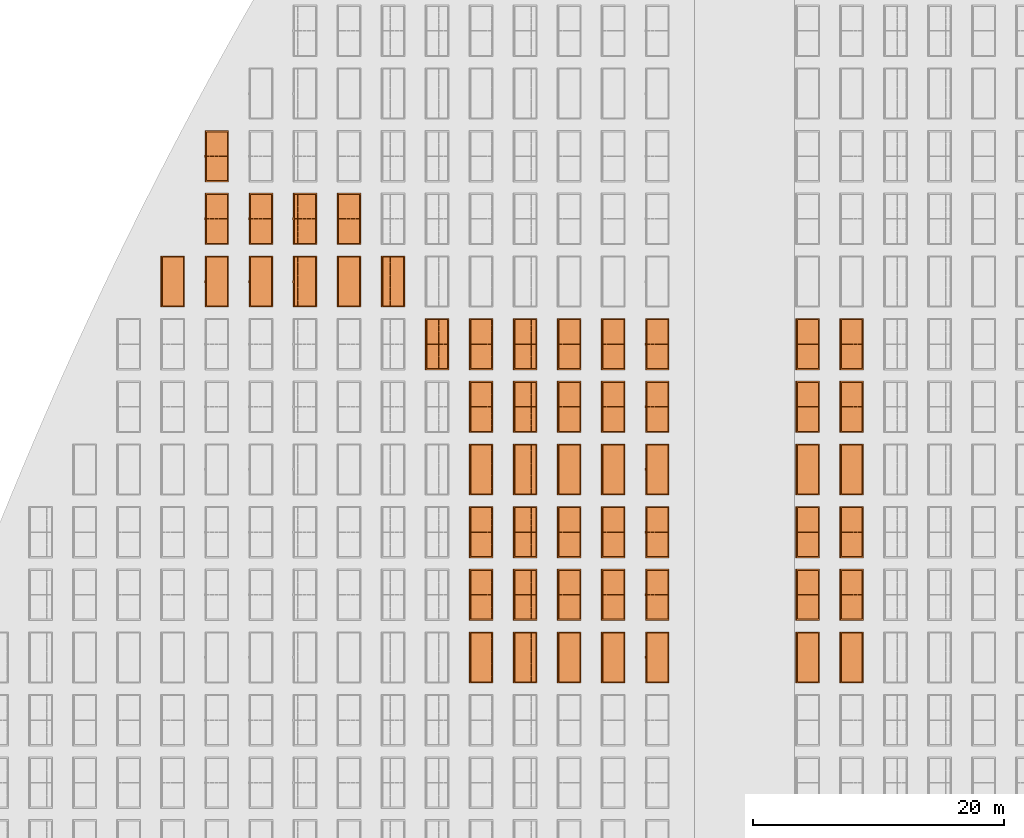
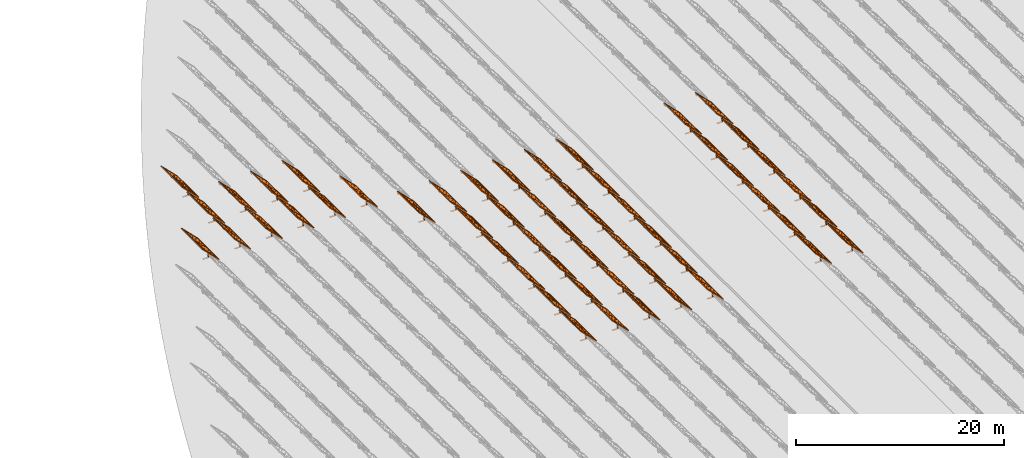
# One storey, part 28 of 39: 54 proxies.
"""IFC2X3 building model written with IfcOpenShell, lengths in millimetres."""

from ifc_helpers import new_model, entity, si_unit, converted_unit, derived_unit, direction, frame, frame_2d, origin, origin_2d_with_axis, place, context, subcontext, project, spatial, polyline, rectangle, outline, extrude, source, transform, mapped, material, material_list, element, save


model = new_model("IFC2X3")

# Units and contexts
model_context = context("Model", 3, precision=1e-06, world=origin(), true_north=direction((2.0, 6.12303176911189e-17, 1.0)))
context_of_model = context(None, 3, precision=1e-06, world=origin(), true_north=direction((2.0, 6.12303176911189e-17, 1.0)))
body_context = subcontext(model_context, "Body", "Model", "MODEL_VIEW")
ifc_project = project(units=[si_unit("LENGTHUNIT", "METRE", prefix="MILLI"), si_unit("AREAUNIT", "SQUARE_METRE", prefix="MILLI"), si_unit("VOLUMEUNIT", "CUBIC_METRE", prefix="MILLI"), converted_unit("PLANEANGLEUNIT", "DEGREE", entity("IfcRatioMeasure", 0.0174532925199433), si_unit("PLANEANGLEUNIT", "RADIAN"), dimensions=[0, 0, 0, 0, 0, 0, 0]), si_unit("MASSUNIT", "GRAM", prefix="KILO"), si_unit("TIMEUNIT", "SECOND"), si_unit("THERMODYNAMICTEMPERATUREUNIT", "KELVIN"), derived_unit("THERMALTRANSMITTANCEUNIT", [(si_unit("MASSUNIT", "GRAM", prefix="KILO"), 1), (si_unit("THERMODYNAMICTEMPERATUREUNIT", "KELVIN"), -1), (si_unit("TIMEUNIT", "SECOND"), -3)]), derived_unit("VOLUMETRICFLOWRATEUNIT", [(si_unit("LENGTHUNIT", "METRE"), 3), (si_unit("TIMEUNIT", "SECOND"), -1)])], contexts=[model_context, context_of_model])

# Site, building, storey
site_placement = place(None, origin())
site = spatial("IfcSite", under=ifc_project, at=site_placement, CompositionType="ELEMENT")
building_placement = place(site_placement, origin())
building = spatial("IfcBuilding", under=site, at=building_placement, CompositionType="ELEMENT")
storey_placement = place(building_placement, frame((0.0, 0.0, 4000.0)))
storey = spatial("IfcBuildingStorey", under=building, at=storey_placement, Name="Level 2", CompositionType="ELEMENT", Elevation=4000.0)

# Proxies
ifc_material_1 = material(Name="Stand-Steel")
ifc_material_2 = material(Name="Aluminium")
ifc_material_3 = material(Name="Glass")
ifc_material_list_1 = material_list([ifc_material_1, ifc_material_2, ifc_material_3])
shared_shape = source(origin(), body_context, "Body", "SweptSolid", [
    extrude(outline(polyline([(-629.526235435404, -220.0), (329.763117717702, -220.0), (329.763117717703, 410.0), (299.763117717703, 410.0), (299.763117717702, -190.0), (-629.526235435404, -190.0), (-629.526235435404, -220.0)])), frame((-190.00003127179, -100.0, 299.763117717707), z_axis=(0.0, 1.0, 0.0), x_axis=(0.0, 0.0, -1.0)), (0.0, 0.0, 1.0), 200.0),
    extrude(rectangle(XDim=20.0000000000001, YDim=200.0, at=frame_2d((0.0, -7.105427357601e-14), x_axis=(0.0, 1.0))), frame((-7.07109908365613, 0.0, 922.21828534124), z_axis=(-0.70710678118654, 0.0, 0.707106781186555), x_axis=(0.0, 1.0, 0.0)), (0.0, 0.0, 1.0), 2600.0),
    extrude(rectangle(XDim=24.9999999999997, YDim=24.9999999999999, at=frame_2d((2.87769807982841e-13, -9.50350909079134e-14), x_axis=(1.0, 0.0))), frame((-1449.56292018118, -1950.0, 2449.57494522722), z_axis=(0.0, 1.0, 0.0), x_axis=(-0.707106781186548, 0.0, -0.707106781186548)), (0.0, 0.0, 1.0), 3900.0),
    extrude(rectangle(XDim=24.9999999999999, YDim=25.0000000000001, at=origin_2d_with_axis()), frame((-1096.0095295879, -1950.0, 2096.02155463395), z_axis=(0.0, 1.0, 0.0), x_axis=(-0.707106781186542, 0.0, -0.707106781186553)), (0.0, 0.0, 1.0), 3900.0),
    extrude(rectangle(XDim=24.9999999999999, YDim=25.0000000000001, at=origin_2d_with_axis()), frame((-742.456138994631, -1950.0, 1742.46816404067), z_axis=(0.0, 1.0, 0.0), x_axis=(-0.707106781186542, 0.0, -0.707106781186553)), (0.0, 0.0, 1.0), 3900.0),
    extrude(rectangle(XDim=25.0, YDim=24.9999999999997, at=frame_2d((-7.19424519957101e-14, 1.19904086659517e-13), x_axis=(1.0, 0.0))), frame((-388.902748401358, -1950.0, 1388.9147734474), z_axis=(0.0, 1.0, 0.0), x_axis=(-0.707106781186545, 0.0, -0.70710678118655)), (0.0, 0.0, 1.0), 3900.0),
    extrude(rectangle(XDim=25.0000000000002, YDim=25.0, at=frame_2d((1.35891298214119e-13, 6.21724893790088e-15), x_axis=(0.0, 1.0))), frame((-35.3553703311048, 1500.0, 1035.35537033109), z_axis=(-0.707106781186544, 0.0, 0.707106781186551), x_axis=(0.0, 1.0, 0.0)), (0.0, 0.0, 1.0), 2440.0),
    extrude(rectangle(XDim=25.0000000000002, YDim=25.0, at=frame_2d((0.0, 1.77635683940025e-15), x_axis=(0.0, 1.0))), frame((-35.3553703311059, 1000.0, 1035.35537033109), z_axis=(-0.707106781186546, 0.0, 0.707106781186549), x_axis=(0.0, 1.0, 0.0)), (0.0, 0.0, 1.0), 2440.0),
    extrude(rectangle(XDim=25.0000000000002, YDim=25.0, at=frame_2d((0.0, 8.43769498715119e-14), x_axis=(0.0, 1.0))), frame((-26.5165355662756, 0.0, 1044.19420509593), z_axis=(-0.707106781186546, 0.0, 0.707106781186549), x_axis=(0.0, -1.0, 0.0)), (0.0, 0.0, 1.0), 2440.0),
    extrude(rectangle(XDim=25.0000000000002, YDim=25.0, at=frame_2d((0.0, 8.88178419700125e-16), x_axis=(0.0, 1.0))), frame((-35.3553703311065, 500.0, 1035.35537033109), z_axis=(-0.707106781186546, 0.0, 0.707106781186549), x_axis=(0.0, 1.0, 0.0)), (0.0, 0.0, 1.0), 2440.0),
    extrude(rectangle(XDim=25.0000000000002, YDim=25.0, at=frame_2d((0.0, 8.88178419700125e-16), x_axis=(0.0, 1.0))), frame((-35.3553703311086, -500.0, 1035.35537033109), z_axis=(-0.707106781186546, 0.0, 0.707106781186549), x_axis=(0.0, 1.0, 0.0)), (0.0, 0.0, 1.0), 2440.0),
    extrude(rectangle(XDim=25.0000000000002, YDim=25.0, at=frame_2d((0.0, 8.88178419700125e-16), x_axis=(0.0, 1.0))), frame((-35.3553703311095, -1000.0, 1035.35537033109), z_axis=(-0.707106781186546, 0.0, 0.707106781186549), x_axis=(0.0, 1.0, 0.0)), (0.0, 0.0, 1.0), 2440.0),
    extrude(rectangle(XDim=25.0000000000002, YDim=25.0, at=frame_2d((1.35891298214119e-13, 1.77635683940025e-15), x_axis=(0.0, 1.0))), frame((-35.3553703311107, -1500.0, 1035.35537033109), z_axis=(-0.707106781186546, 0.0, 0.707106781186549), x_axis=(0.0, 1.0, 0.0)), (0.0, 0.0, 1.0), 2440.0),
    extrude(rectangle(XDim=2400.0, YDim=11.9999999999994, at=frame_2d((-1.13686837721616e-13, 2.02948768901479e-13), x_axis=(1.0, 0.0))), frame((-883.883507754966, -1950.0, 1883.88350775495), z_axis=(0.0, 1.0, 0.0), x_axis=(0.707106781186546, 0.0, -0.707106781186549)), (0.0, 0.0, 1.0), 3900.0),
    extrude(outline(polyline([(-2050.0, -1300.0), (2050.0, -1300.0), (2050.0, 1300.0), (-2050.0, 1300.0), (-2050.0, -1300.0)]), holes=[polyline([(1950.0, -1200.0), (-1950.0, -1200.0), (-1950.0, 1200.0), (1950.0, 1200.0), (1950.0, -1200.0)])]), frame((-919.238846814293, 0.0, 1848.52816869563), z_axis=(0.707106781186554, 0.0, 0.707106781186541), x_axis=(0.0, 1.0, 0.0)), (0.0, 0.0, 1.0), 99.9999999999898),
])
proxy_1_placement = place(storey_placement, frame((-144385.32831183, 565144.680552408, 30.0)))
element("IfcBuildingElementProxy", 1, at=proxy_1_placement, inside=storey, material=ifc_material_list_1, Name="Solar Panel_4000X2500:Solar Panel_4000X2500", ObjectType="Solar Panel_4000X2500", CompositionType="ELEMENT", context=body_context, shape_type="MappedRepresentation", body=[
    mapped(shared_shape, transform((0.0, 0.0, 0.0), scale=1.0)),
])
ifc_material_list_2 = material_list([ifc_material_1, ifc_material_2, ifc_material_3])
proxy_2_placement = place(storey_placement, frame((-144385.32831183, 570144.680552408, 30.0)))
element("IfcBuildingElementProxy", 2, at=proxy_2_placement, inside=storey, material=ifc_material_list_2, Name="Solar Panel_4000X2500:Solar Panel_4000X2500", ObjectType="Solar Panel_4000X2500", CompositionType="ELEMENT", context=body_context, shape_type="MappedRepresentation", body=[
    mapped(shared_shape, transform((0.0, 0.0, 0.0), scale=1.0)),
])
ifc_material_list_3 = material_list([ifc_material_1, ifc_material_2, ifc_material_3])
proxy_3_placement = place(storey_placement, frame((-144385.32831183, 575144.680552408, 30.0)))
element("IfcBuildingElementProxy", 3, at=proxy_3_placement, inside=storey, material=ifc_material_list_3, Name="Solar Panel_4000X2500:Solar Panel_4000X2500", ObjectType="Solar Panel_4000X2500", CompositionType="ELEMENT", context=body_context, shape_type="MappedRepresentation", body=[
    mapped(shared_shape, transform((0.0, 0.0, 0.0), scale=1.0)),
])
ifc_material_list_4 = material_list([ifc_material_1, ifc_material_2, ifc_material_3])
proxy_4_placement = place(storey_placement, frame((-144385.32831183, 580144.680552408, 30.0)))
element("IfcBuildingElementProxy", 4, at=proxy_4_placement, inside=storey, material=ifc_material_list_4, Name="Solar Panel_4000X2500:Solar Panel_4000X2500", ObjectType="Solar Panel_4000X2500", CompositionType="ELEMENT", context=body_context, shape_type="MappedRepresentation", body=[
    mapped(shared_shape, transform((0.0, 0.0, 0.0), scale=1.0)),
])
ifc_material_list_5 = material_list([ifc_material_1, ifc_material_2, ifc_material_3])
proxy_5_placement = place(storey_placement, frame((-144385.32831183, 585144.680552408, 30.0)))
element("IfcBuildingElementProxy", 5, at=proxy_5_placement, inside=storey, material=ifc_material_list_5, Name="Solar Panel_4000X2500:Solar Panel_4000X2500", ObjectType="Solar Panel_4000X2500", CompositionType="ELEMENT", context=body_context, shape_type="MappedRepresentation", body=[
    mapped(shared_shape, transform((0.0, 0.0, 0.0), scale=1.0)),
])
ifc_material_list_6 = material_list([ifc_material_1, ifc_material_2, ifc_material_3])
proxy_6_placement = place(storey_placement, frame((-144385.32831183, 590144.680552408, 30.0)))
element("IfcBuildingElementProxy", 6, at=proxy_6_placement, inside=storey, material=ifc_material_list_6, Name="Solar Panel_4000X2500:Solar Panel_4000X2500", ObjectType="Solar Panel_4000X2500", CompositionType="ELEMENT", context=body_context, shape_type="MappedRepresentation", body=[
    mapped(shared_shape, transform((0.0, 0.0, 0.0), scale=1.0)),
])
ifc_material_list_7 = material_list([ifc_material_1, ifc_material_2, ifc_material_3])
proxy_7_placement = place(storey_placement, frame((-147885.32831183, 565144.680552408, 30.0)))
element("IfcBuildingElementProxy", 7, at=proxy_7_placement, inside=storey, material=ifc_material_list_7, Name="Solar Panel_4000X2500:Solar Panel_4000X2500", ObjectType="Solar Panel_4000X2500", CompositionType="ELEMENT", context=body_context, shape_type="MappedRepresentation", body=[
    mapped(shared_shape, transform((0.0, 0.0, 0.0), scale=1.0)),
])
ifc_material_list_8 = material_list([ifc_material_1, ifc_material_2, ifc_material_3])
proxy_8_placement = place(storey_placement, frame((-147885.32831183, 570144.680552408, 30.0)))
element("IfcBuildingElementProxy", 8, at=proxy_8_placement, inside=storey, material=ifc_material_list_8, Name="Solar Panel_4000X2500:Solar Panel_4000X2500", ObjectType="Solar Panel_4000X2500", CompositionType="ELEMENT", context=body_context, shape_type="MappedRepresentation", body=[
    mapped(shared_shape, transform((0.0, 0.0, 0.0), scale=1.0)),
])
ifc_material_list_9 = material_list([ifc_material_1, ifc_material_2, ifc_material_3])
proxy_9_placement = place(storey_placement, frame((-147885.32831183, 575144.680552408, 30.0)))
element("IfcBuildingElementProxy", 9, at=proxy_9_placement, inside=storey, material=ifc_material_list_9, Name="Solar Panel_4000X2500:Solar Panel_4000X2500", ObjectType="Solar Panel_4000X2500", CompositionType="ELEMENT", context=body_context, shape_type="MappedRepresentation", body=[
    mapped(shared_shape, transform((0.0, 0.0, 0.0), scale=1.0)),
])
ifc_material_list_10 = material_list([ifc_material_1, ifc_material_2, ifc_material_3])
proxy_10_placement = place(storey_placement, frame((-147885.32831183, 580144.680552408, 30.0)))
element("IfcBuildingElementProxy", 10, at=proxy_10_placement, inside=storey, material=ifc_material_list_10, Name="Solar Panel_4000X2500:Solar Panel_4000X2500", ObjectType="Solar Panel_4000X2500", CompositionType="ELEMENT", context=body_context, shape_type="MappedRepresentation", body=[
    mapped(shared_shape, transform((0.0, 0.0, 0.0), scale=1.0)),
])
ifc_material_list_11 = material_list([ifc_material_1, ifc_material_2, ifc_material_3])
proxy_11_placement = place(storey_placement, frame((-147885.32831183, 585144.680552408, 30.0)))
element("IfcBuildingElementProxy", 11, at=proxy_11_placement, inside=storey, material=ifc_material_list_11, Name="Solar Panel_4000X2500:Solar Panel_4000X2500", ObjectType="Solar Panel_4000X2500", CompositionType="ELEMENT", context=body_context, shape_type="MappedRepresentation", body=[
    mapped(shared_shape, transform((0.0, 0.0, 0.0), scale=1.0)),
])
ifc_material_list_12 = material_list([ifc_material_1, ifc_material_2, ifc_material_3])
proxy_12_placement = place(storey_placement, frame((-147885.32831183, 590144.680552408, 30.0)))
element("IfcBuildingElementProxy", 12, at=proxy_12_placement, inside=storey, material=ifc_material_list_12, Name="Solar Panel_4000X2500:Solar Panel_4000X2500", ObjectType="Solar Panel_4000X2500", CompositionType="ELEMENT", context=body_context, shape_type="MappedRepresentation", body=[
    mapped(shared_shape, transform((0.0, 0.0, 0.0), scale=1.0)),
])
ifc_material_list_13 = material_list([ifc_material_1, ifc_material_2, ifc_material_3])
proxy_13_placement = place(storey_placement, frame((-159885.32831183, 565144.680552408, 30.0)))
element("IfcBuildingElementProxy", 13, at=proxy_13_placement, inside=storey, material=ifc_material_list_13, Name="Solar Panel_4000X2500:Solar Panel_4000X2500", ObjectType="Solar Panel_4000X2500", CompositionType="ELEMENT", context=body_context, shape_type="MappedRepresentation", body=[
    mapped(shared_shape, transform((0.0, 0.0, 0.0), scale=1.0)),
])
ifc_material_list_14 = material_list([ifc_material_1, ifc_material_2, ifc_material_3])
proxy_14_placement = place(storey_placement, frame((-159885.32831183, 570144.680552408, 30.0)))
element("IfcBuildingElementProxy", 14, at=proxy_14_placement, inside=storey, material=ifc_material_list_14, Name="Solar Panel_4000X2500:Solar Panel_4000X2500", ObjectType="Solar Panel_4000X2500", CompositionType="ELEMENT", context=body_context, shape_type="MappedRepresentation", body=[
    mapped(shared_shape, transform((0.0, 0.0, 0.0), scale=1.0)),
])
ifc_material_list_15 = material_list([ifc_material_1, ifc_material_2, ifc_material_3])
proxy_15_placement = place(storey_placement, frame((-159885.32831183, 575144.680552408, 30.0)))
element("IfcBuildingElementProxy", 15, at=proxy_15_placement, inside=storey, material=ifc_material_list_15, Name="Solar Panel_4000X2500:Solar Panel_4000X2500", ObjectType="Solar Panel_4000X2500", CompositionType="ELEMENT", context=body_context, shape_type="MappedRepresentation", body=[
    mapped(shared_shape, transform((0.0, 0.0, 0.0), scale=1.0)),
])
ifc_material_list_16 = material_list([ifc_material_1, ifc_material_2, ifc_material_3])
proxy_16_placement = place(storey_placement, frame((-159885.32831183, 580144.680552408, 30.0)))
element("IfcBuildingElementProxy", 16, at=proxy_16_placement, inside=storey, material=ifc_material_list_16, Name="Solar Panel_4000X2500:Solar Panel_4000X2500", ObjectType="Solar Panel_4000X2500", CompositionType="ELEMENT", context=body_context, shape_type="MappedRepresentation", body=[
    mapped(shared_shape, transform((0.0, 0.0, 0.0), scale=1.0)),
])
ifc_material_list_17 = material_list([ifc_material_1, ifc_material_2, ifc_material_3])
proxy_17_placement = place(storey_placement, frame((-159885.32831183, 585144.680552408, 30.0)))
element("IfcBuildingElementProxy", 17, at=proxy_17_placement, inside=storey, material=ifc_material_list_17, Name="Solar Panel_4000X2500:Solar Panel_4000X2500", ObjectType="Solar Panel_4000X2500", CompositionType="ELEMENT", context=body_context, shape_type="MappedRepresentation", body=[
    mapped(shared_shape, transform((0.0, 0.0, 0.0), scale=1.0)),
])
ifc_material_list_18 = material_list([ifc_material_1, ifc_material_2, ifc_material_3])
proxy_18_placement = place(storey_placement, frame((-159885.32831183, 590144.680552408, 30.0)))
element("IfcBuildingElementProxy", 18, at=proxy_18_placement, inside=storey, material=ifc_material_list_18, Name="Solar Panel_4000X2500:Solar Panel_4000X2500", ObjectType="Solar Panel_4000X2500", CompositionType="ELEMENT", context=body_context, shape_type="MappedRepresentation", body=[
    mapped(shared_shape, transform((0.0, 0.0, 0.0), scale=1.0)),
])
ifc_material_list_19 = material_list([ifc_material_1, ifc_material_2, ifc_material_3])
proxy_19_placement = place(storey_placement, frame((-163400.32831183, 565144.680552408, 30.0)))
element("IfcBuildingElementProxy", 19, at=proxy_19_placement, inside=storey, material=ifc_material_list_19, Name="Solar Panel_4000X2500:Solar Panel_4000X2500", ObjectType="Solar Panel_4000X2500", CompositionType="ELEMENT", context=body_context, shape_type="MappedRepresentation", body=[
    mapped(shared_shape, transform((0.0, 0.0, 0.0), scale=1.0)),
])
ifc_material_list_20 = material_list([ifc_material_1, ifc_material_2, ifc_material_3])
proxy_20_placement = place(storey_placement, frame((-163400.32831183, 570144.680552408, 30.0)))
element("IfcBuildingElementProxy", 20, at=proxy_20_placement, inside=storey, material=ifc_material_list_20, Name="Solar Panel_4000X2500:Solar Panel_4000X2500", ObjectType="Solar Panel_4000X2500", CompositionType="ELEMENT", context=body_context, shape_type="MappedRepresentation", body=[
    mapped(shared_shape, transform((0.0, 0.0, 0.0), scale=1.0)),
])
ifc_material_list_21 = material_list([ifc_material_1, ifc_material_2, ifc_material_3])
proxy_21_placement = place(storey_placement, frame((-163400.32831183, 575144.680552408, 30.0)))
element("IfcBuildingElementProxy", 21, at=proxy_21_placement, inside=storey, material=ifc_material_list_21, Name="Solar Panel_4000X2500:Solar Panel_4000X2500", ObjectType="Solar Panel_4000X2500", CompositionType="ELEMENT", context=body_context, shape_type="MappedRepresentation", body=[
    mapped(shared_shape, transform((0.0, 0.0, 0.0), scale=1.0)),
])
ifc_material_list_22 = material_list([ifc_material_1, ifc_material_2, ifc_material_3])
proxy_22_placement = place(storey_placement, frame((-163400.32831183, 580144.680552408, 30.0)))
element("IfcBuildingElementProxy", 22, at=proxy_22_placement, inside=storey, material=ifc_material_list_22, Name="Solar Panel_4000X2500:Solar Panel_4000X2500", ObjectType="Solar Panel_4000X2500", CompositionType="ELEMENT", context=body_context, shape_type="MappedRepresentation", body=[
    mapped(shared_shape, transform((0.0, 0.0, 0.0), scale=1.0)),
])
ifc_material_list_23 = material_list([ifc_material_1, ifc_material_2, ifc_material_3])
proxy_23_placement = place(storey_placement, frame((-163400.32831183, 585144.680552408, 30.0)))
element("IfcBuildingElementProxy", 23, at=proxy_23_placement, inside=storey, material=ifc_material_list_23, Name="Solar Panel_4000X2500:Solar Panel_4000X2500", ObjectType="Solar Panel_4000X2500", CompositionType="ELEMENT", context=body_context, shape_type="MappedRepresentation", body=[
    mapped(shared_shape, transform((0.0, 0.0, 0.0), scale=1.0)),
])
ifc_material_list_24 = material_list([ifc_material_1, ifc_material_2, ifc_material_3])
proxy_24_placement = place(storey_placement, frame((-163400.32831183, 590144.680552408, 30.0)))
element("IfcBuildingElementProxy", 24, at=proxy_24_placement, inside=storey, material=ifc_material_list_24, Name="Solar Panel_4000X2500:Solar Panel_4000X2500", ObjectType="Solar Panel_4000X2500", CompositionType="ELEMENT", context=body_context, shape_type="MappedRepresentation", body=[
    mapped(shared_shape, transform((0.0, 0.0, 0.0), scale=1.0)),
])
ifc_material_list_25 = material_list([ifc_material_1, ifc_material_2, ifc_material_3])
proxy_25_placement = place(storey_placement, frame((-166915.32831183, 565144.680552408, 30.0)))
element("IfcBuildingElementProxy", 25, at=proxy_25_placement, inside=storey, material=ifc_material_list_25, Name="Solar Panel_4000X2500:Solar Panel_4000X2500", ObjectType="Solar Panel_4000X2500", CompositionType="ELEMENT", context=body_context, shape_type="MappedRepresentation", body=[
    mapped(shared_shape, transform((0.0, 0.0, 0.0), scale=1.0)),
])
ifc_material_list_26 = material_list([ifc_material_1, ifc_material_2, ifc_material_3])
proxy_26_placement = place(storey_placement, frame((-166915.32831183, 570144.680552408, 30.0)))
element("IfcBuildingElementProxy", 26, at=proxy_26_placement, inside=storey, material=ifc_material_list_26, Name="Solar Panel_4000X2500:Solar Panel_4000X2500", ObjectType="Solar Panel_4000X2500", CompositionType="ELEMENT", context=body_context, shape_type="MappedRepresentation", body=[
    mapped(shared_shape, transform((0.0, 0.0, 0.0), scale=1.0)),
])
ifc_material_list_27 = material_list([ifc_material_1, ifc_material_2, ifc_material_3])
proxy_27_placement = place(storey_placement, frame((-166915.32831183, 575144.680552408, 30.0)))
element("IfcBuildingElementProxy", 27, at=proxy_27_placement, inside=storey, material=ifc_material_list_27, Name="Solar Panel_4000X2500:Solar Panel_4000X2500", ObjectType="Solar Panel_4000X2500", CompositionType="ELEMENT", context=body_context, shape_type="MappedRepresentation", body=[
    mapped(shared_shape, transform((0.0, 0.0, 0.0), scale=1.0)),
])
ifc_material_list_28 = material_list([ifc_material_1, ifc_material_2, ifc_material_3])
proxy_28_placement = place(storey_placement, frame((-166915.32831183, 580144.680552408, 30.0)))
element("IfcBuildingElementProxy", 28, at=proxy_28_placement, inside=storey, material=ifc_material_list_28, Name="Solar Panel_4000X2500:Solar Panel_4000X2500", ObjectType="Solar Panel_4000X2500", CompositionType="ELEMENT", context=body_context, shape_type="MappedRepresentation", body=[
    mapped(shared_shape, transform((0.0, 0.0, 0.0), scale=1.0)),
])
ifc_material_list_29 = material_list([ifc_material_1, ifc_material_2, ifc_material_3])
proxy_29_placement = place(storey_placement, frame((-166915.32831183, 585144.680552408, 30.0)))
element("IfcBuildingElementProxy", 29, at=proxy_29_placement, inside=storey, material=ifc_material_list_29, Name="Solar Panel_4000X2500:Solar Panel_4000X2500", ObjectType="Solar Panel_4000X2500", CompositionType="ELEMENT", context=body_context, shape_type="MappedRepresentation", body=[
    mapped(shared_shape, transform((0.0, 0.0, 0.0), scale=1.0)),
])
ifc_material_list_30 = material_list([ifc_material_1, ifc_material_2, ifc_material_3])
proxy_30_placement = place(storey_placement, frame((-166915.32831183, 590144.680552408, 30.0)))
element("IfcBuildingElementProxy", 30, at=proxy_30_placement, inside=storey, material=ifc_material_list_30, Name="Solar Panel_4000X2500:Solar Panel_4000X2500", ObjectType="Solar Panel_4000X2500", CompositionType="ELEMENT", context=body_context, shape_type="MappedRepresentation", body=[
    mapped(shared_shape, transform((0.0, 0.0, 0.0), scale=1.0)),
])
ifc_material_list_31 = material_list([ifc_material_1, ifc_material_2, ifc_material_3])
proxy_31_placement = place(storey_placement, frame((-170430.32831183, 565144.680552408, 30.0)))
element("IfcBuildingElementProxy", 31, at=proxy_31_placement, inside=storey, material=ifc_material_list_31, Name="Solar Panel_4000X2500:Solar Panel_4000X2500", ObjectType="Solar Panel_4000X2500", CompositionType="ELEMENT", context=body_context, shape_type="MappedRepresentation", body=[
    mapped(shared_shape, transform((0.0, 0.0, 0.0), scale=1.0)),
])
ifc_material_list_32 = material_list([ifc_material_1, ifc_material_2, ifc_material_3])
proxy_32_placement = place(storey_placement, frame((-170430.32831183, 570144.680552408, 30.0)))
element("IfcBuildingElementProxy", 32, at=proxy_32_placement, inside=storey, material=ifc_material_list_32, Name="Solar Panel_4000X2500:Solar Panel_4000X2500", ObjectType="Solar Panel_4000X2500", CompositionType="ELEMENT", context=body_context, shape_type="MappedRepresentation", body=[
    mapped(shared_shape, transform((0.0, 0.0, 0.0), scale=1.0)),
])
ifc_material_list_33 = material_list([ifc_material_1, ifc_material_2, ifc_material_3])
proxy_33_placement = place(storey_placement, frame((-170430.32831183, 575144.680552408, 30.0)))
element("IfcBuildingElementProxy", 33, at=proxy_33_placement, inside=storey, material=ifc_material_list_33, Name="Solar Panel_4000X2500:Solar Panel_4000X2500", ObjectType="Solar Panel_4000X2500", CompositionType="ELEMENT", context=body_context, shape_type="MappedRepresentation", body=[
    mapped(shared_shape, transform((0.0, 0.0, 0.0), scale=1.0)),
])
ifc_material_list_34 = material_list([ifc_material_1, ifc_material_2, ifc_material_3])
proxy_34_placement = place(storey_placement, frame((-170430.32831183, 580144.680552408, 30.0)))
element("IfcBuildingElementProxy", 34, at=proxy_34_placement, inside=storey, material=ifc_material_list_34, Name="Solar Panel_4000X2500:Solar Panel_4000X2500", ObjectType="Solar Panel_4000X2500", CompositionType="ELEMENT", context=body_context, shape_type="MappedRepresentation", body=[
    mapped(shared_shape, transform((0.0, 0.0, 0.0), scale=1.0)),
])
ifc_material_list_35 = material_list([ifc_material_1, ifc_material_2, ifc_material_3])
proxy_35_placement = place(storey_placement, frame((-170430.32831183, 585144.680552408, 30.0)))
element("IfcBuildingElementProxy", 35, at=proxy_35_placement, inside=storey, material=ifc_material_list_35, Name="Solar Panel_4000X2500:Solar Panel_4000X2500", ObjectType="Solar Panel_4000X2500", CompositionType="ELEMENT", context=body_context, shape_type="MappedRepresentation", body=[
    mapped(shared_shape, transform((0.0, 0.0, 0.0), scale=1.0)),
])
ifc_material_list_36 = material_list([ifc_material_1, ifc_material_2, ifc_material_3])
proxy_36_placement = place(storey_placement, frame((-170430.32831183, 590144.680552408, 30.0)))
element("IfcBuildingElementProxy", 36, at=proxy_36_placement, inside=storey, material=ifc_material_list_36, Name="Solar Panel_4000X2500:Solar Panel_4000X2500", ObjectType="Solar Panel_4000X2500", CompositionType="ELEMENT", context=body_context, shape_type="MappedRepresentation", body=[
    mapped(shared_shape, transform((0.0, 0.0, 0.0), scale=1.0)),
])
ifc_material_list_37 = material_list([ifc_material_1, ifc_material_2, ifc_material_3])
proxy_37_placement = place(storey_placement, frame((-173945.32831183, 565144.680552408, 30.0)))
element("IfcBuildingElementProxy", 37, at=proxy_37_placement, inside=storey, material=ifc_material_list_37, Name="Solar Panel_4000X2500:Solar Panel_4000X2500", ObjectType="Solar Panel_4000X2500", CompositionType="ELEMENT", context=body_context, shape_type="MappedRepresentation", body=[
    mapped(shared_shape, transform((0.0, 0.0, 0.0), scale=1.0)),
])
ifc_material_list_38 = material_list([ifc_material_1, ifc_material_2, ifc_material_3])
proxy_38_placement = place(storey_placement, frame((-173945.32831183, 570144.680552408, 30.0)))
element("IfcBuildingElementProxy", 38, at=proxy_38_placement, inside=storey, material=ifc_material_list_38, Name="Solar Panel_4000X2500:Solar Panel_4000X2500", ObjectType="Solar Panel_4000X2500", CompositionType="ELEMENT", context=body_context, shape_type="MappedRepresentation", body=[
    mapped(shared_shape, transform((0.0, 0.0, 0.0), scale=1.0)),
])
ifc_material_list_39 = material_list([ifc_material_1, ifc_material_2, ifc_material_3])
proxy_39_placement = place(storey_placement, frame((-173945.32831183, 575144.680552408, 30.0)))
element("IfcBuildingElementProxy", 39, at=proxy_39_placement, inside=storey, material=ifc_material_list_39, Name="Solar Panel_4000X2500:Solar Panel_4000X2500", ObjectType="Solar Panel_4000X2500", CompositionType="ELEMENT", context=body_context, shape_type="MappedRepresentation", body=[
    mapped(shared_shape, transform((0.0, 0.0, 0.0), scale=1.0)),
])
ifc_material_list_40 = material_list([ifc_material_1, ifc_material_2, ifc_material_3])
proxy_40_placement = place(storey_placement, frame((-173945.32831183, 580144.680552408, 30.0)))
element("IfcBuildingElementProxy", 40, at=proxy_40_placement, inside=storey, material=ifc_material_list_40, Name="Solar Panel_4000X2500:Solar Panel_4000X2500", ObjectType="Solar Panel_4000X2500", CompositionType="ELEMENT", context=body_context, shape_type="MappedRepresentation", body=[
    mapped(shared_shape, transform((0.0, 0.0, 0.0), scale=1.0)),
])
ifc_material_list_41 = material_list([ifc_material_1, ifc_material_2, ifc_material_3])
proxy_41_placement = place(storey_placement, frame((-173945.32831183, 585144.680552408, 30.0)))
element("IfcBuildingElementProxy", 41, at=proxy_41_placement, inside=storey, material=ifc_material_list_41, Name="Solar Panel_4000X2500:Solar Panel_4000X2500", ObjectType="Solar Panel_4000X2500", CompositionType="ELEMENT", context=body_context, shape_type="MappedRepresentation", body=[
    mapped(shared_shape, transform((0.0, 0.0, 0.0), scale=1.0)),
])
ifc_material_list_42 = material_list([ifc_material_1, ifc_material_2, ifc_material_3])
proxy_42_placement = place(storey_placement, frame((-173945.32831183, 590144.680552408, 30.0)))
element("IfcBuildingElementProxy", 42, at=proxy_42_placement, inside=storey, material=ifc_material_list_42, Name="Solar Panel_4000X2500:Solar Panel_4000X2500", ObjectType="Solar Panel_4000X2500", CompositionType="ELEMENT", context=body_context, shape_type="MappedRepresentation", body=[
    mapped(shared_shape, transform((0.0, 0.0, 0.0), scale=1.0)),
])
ifc_material_list_43 = material_list([ifc_material_1, ifc_material_2, ifc_material_3])
proxy_43_placement = place(storey_placement, frame((-177460.32831183, 590144.680552408, 30.0)))
element("IfcBuildingElementProxy", 43, at=proxy_43_placement, inside=storey, material=ifc_material_list_43, Name="Solar Panel_4000X2500:Solar Panel_4000X2500", ObjectType="Solar Panel_4000X2500", CompositionType="ELEMENT", context=body_context, shape_type="MappedRepresentation", body=[
    mapped(shared_shape, transform((0.0, 0.0, 0.0), scale=1.0)),
])
ifc_material_list_44 = material_list([ifc_material_1, ifc_material_2, ifc_material_3])
proxy_44_placement = place(storey_placement, frame((-180975.32831183, 595144.680552408, 30.0)))
element("IfcBuildingElementProxy", 44, at=proxy_44_placement, inside=storey, material=ifc_material_list_44, Name="Solar Panel_4000X2500:Solar Panel_4000X2500", ObjectType="Solar Panel_4000X2500", CompositionType="ELEMENT", context=body_context, shape_type="MappedRepresentation", body=[
    mapped(shared_shape, transform((0.0, 0.0, 0.0), scale=1.0)),
])
ifc_material_list_45 = material_list([ifc_material_1, ifc_material_2, ifc_material_3])
proxy_45_placement = place(storey_placement, frame((-184490.32831183, 595144.680552408, 30.0)))
element("IfcBuildingElementProxy", 45, at=proxy_45_placement, inside=storey, material=ifc_material_list_45, Name="Solar Panel_4000X2500:Solar Panel_4000X2500", ObjectType="Solar Panel_4000X2500", CompositionType="ELEMENT", context=body_context, shape_type="MappedRepresentation", body=[
    mapped(shared_shape, transform((0.0, 0.0, 0.0), scale=1.0)),
])
ifc_material_list_46 = material_list([ifc_material_1, ifc_material_2, ifc_material_3])
proxy_46_placement = place(storey_placement, frame((-184490.32831183, 600144.680552408, 30.0)))
element("IfcBuildingElementProxy", 46, at=proxy_46_placement, inside=storey, material=ifc_material_list_46, Name="Solar Panel_4000X2500:Solar Panel_4000X2500", ObjectType="Solar Panel_4000X2500", CompositionType="ELEMENT", context=body_context, shape_type="MappedRepresentation", body=[
    mapped(shared_shape, transform((0.0, 0.0, 0.0), scale=1.0)),
])
ifc_material_list_47 = material_list([ifc_material_1, ifc_material_2, ifc_material_3])
proxy_47_placement = place(storey_placement, frame((-188005.32831183, 595144.680552408, 30.0)))
element("IfcBuildingElementProxy", 47, at=proxy_47_placement, inside=storey, material=ifc_material_list_47, Name="Solar Panel_4000X2500:Solar Panel_4000X2500", ObjectType="Solar Panel_4000X2500", CompositionType="ELEMENT", context=body_context, shape_type="MappedRepresentation", body=[
    mapped(shared_shape, transform((0.0, 0.0, 0.0), scale=1.0)),
])
ifc_material_list_48 = material_list([ifc_material_1, ifc_material_2, ifc_material_3])
proxy_48_placement = place(storey_placement, frame((-188005.32831183, 600144.680552408, 30.0)))
element("IfcBuildingElementProxy", 48, at=proxy_48_placement, inside=storey, material=ifc_material_list_48, Name="Solar Panel_4000X2500:Solar Panel_4000X2500", ObjectType="Solar Panel_4000X2500", CompositionType="ELEMENT", context=body_context, shape_type="MappedRepresentation", body=[
    mapped(shared_shape, transform((0.0, 0.0, 0.0), scale=1.0)),
])
ifc_material_list_49 = material_list([ifc_material_1, ifc_material_2, ifc_material_3])
proxy_49_placement = place(storey_placement, frame((-191520.32831183, 595144.680552408, 30.0)))
element("IfcBuildingElementProxy", 49, at=proxy_49_placement, inside=storey, material=ifc_material_list_49, Name="Solar Panel_4000X2500:Solar Panel_4000X2500", ObjectType="Solar Panel_4000X2500", CompositionType="ELEMENT", context=body_context, shape_type="MappedRepresentation", body=[
    mapped(shared_shape, transform((0.0, 0.0, 0.0), scale=1.0)),
])
ifc_material_list_50 = material_list([ifc_material_1, ifc_material_2, ifc_material_3])
proxy_50_placement = place(storey_placement, frame((-191520.32831183, 600144.680552408, 30.0)))
element("IfcBuildingElementProxy", 50, at=proxy_50_placement, inside=storey, material=ifc_material_list_50, Name="Solar Panel_4000X2500:Solar Panel_4000X2500", ObjectType="Solar Panel_4000X2500", CompositionType="ELEMENT", context=body_context, shape_type="MappedRepresentation", body=[
    mapped(shared_shape, transform((0.0, 0.0, 0.0), scale=1.0)),
])
ifc_material_list_51 = material_list([ifc_material_1, ifc_material_2, ifc_material_3])
proxy_51_placement = place(storey_placement, frame((-195035.32831183, 595144.680552408, 30.0)))
element("IfcBuildingElementProxy", 51, at=proxy_51_placement, inside=storey, material=ifc_material_list_51, Name="Solar Panel_4000X2500:Solar Panel_4000X2500", ObjectType="Solar Panel_4000X2500", CompositionType="ELEMENT", context=body_context, shape_type="MappedRepresentation", body=[
    mapped(shared_shape, transform((0.0, 0.0, 0.0), scale=1.0)),
])
ifc_material_list_52 = material_list([ifc_material_1, ifc_material_2, ifc_material_3])
proxy_52_placement = place(storey_placement, frame((-195035.32831183, 600144.680552408, 30.0)))
element("IfcBuildingElementProxy", 52, at=proxy_52_placement, inside=storey, material=ifc_material_list_52, Name="Solar Panel_4000X2500:Solar Panel_4000X2500", ObjectType="Solar Panel_4000X2500", CompositionType="ELEMENT", context=body_context, shape_type="MappedRepresentation", body=[
    mapped(shared_shape, transform((0.0, 0.0, 0.0), scale=1.0)),
])
ifc_material_list_53 = material_list([ifc_material_1, ifc_material_2, ifc_material_3])
proxy_53_placement = place(storey_placement, frame((-198550.32831183, 595144.680552408, 30.0)))
element("IfcBuildingElementProxy", 53, at=proxy_53_placement, inside=storey, material=ifc_material_list_53, Name="Solar Panel_4000X2500:Solar Panel_4000X2500", ObjectType="Solar Panel_4000X2500", CompositionType="ELEMENT", context=body_context, shape_type="MappedRepresentation", body=[
    mapped(shared_shape, transform((0.0, 0.0, 0.0), scale=1.0)),
])
ifc_material_list_54 = material_list([ifc_material_1, ifc_material_2, ifc_material_3])
proxy_54_placement = place(storey_placement, frame((-195035.32831183, 605144.680552408, 30.0)))
element("IfcBuildingElementProxy", 54, at=proxy_54_placement, inside=storey, material=ifc_material_list_54, Name="Solar Panel_4000X2500:Solar Panel_4000X2500", ObjectType="Solar Panel_4000X2500", CompositionType="ELEMENT", context=body_context, shape_type="MappedRepresentation", body=[
    mapped(shared_shape, transform((0.0, 0.0, 0.0), scale=1.0)),
])

save(model, "model.ifc")
